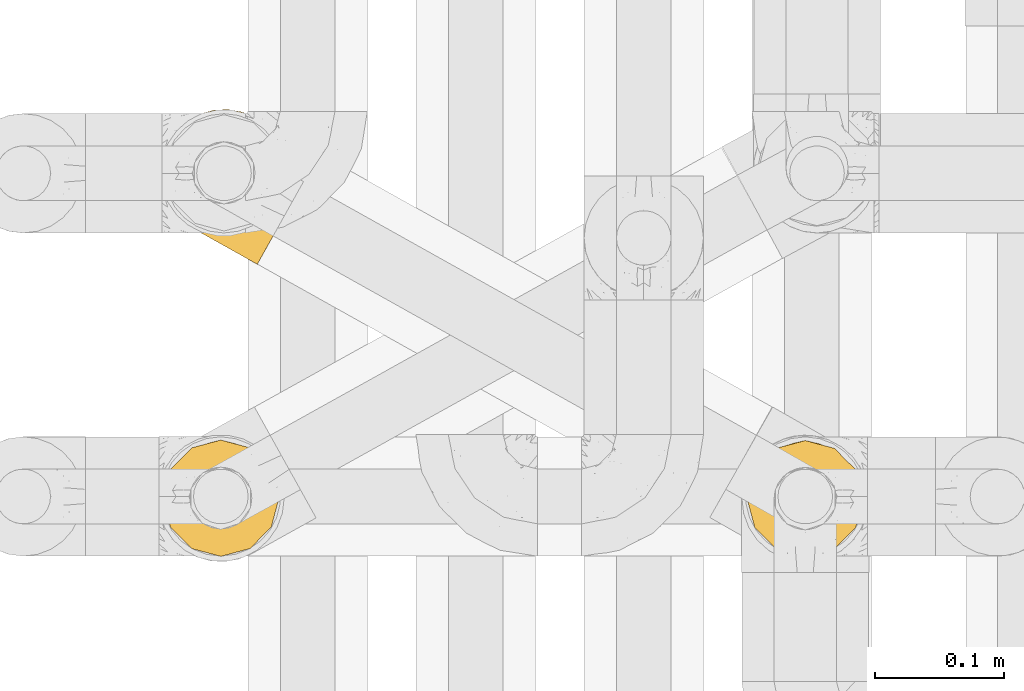
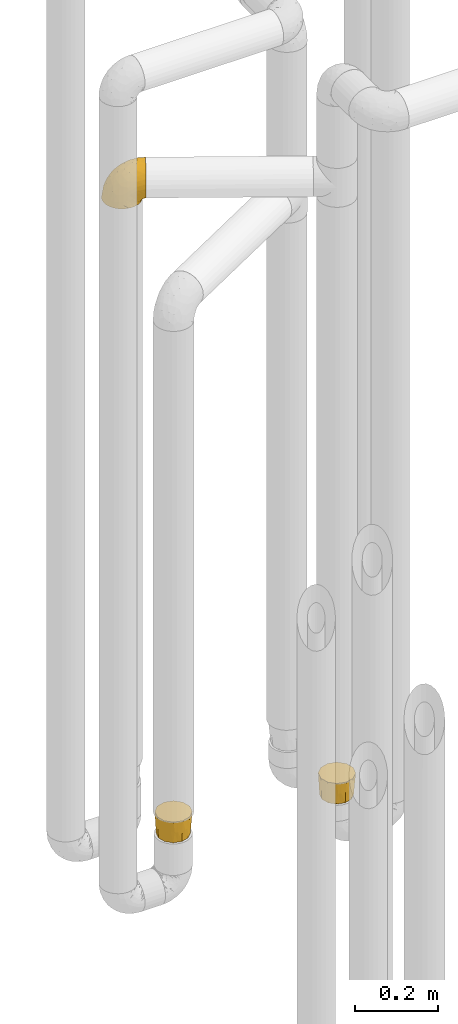
# One storey, part 178 of 827: 3 coverings.
"""IFC2X3 building model written with IfcOpenShell, lengths in millimetres."""

from ifc_helpers import new_model, entity, si_unit, converted_unit, derived_unit, direction, frame, origin, place, context, subcontext, project, spatial, faceted_brep, element, save


model = new_model("IFC2X3")

# Units and contexts
model_context = context("Model", 3, precision=0.01, world=origin(), true_north=direction((6.12303176911189e-17, 1.0)))
body_context = subcontext(model_context, "Body", "Model", "MODEL_VIEW")
ifc_project = project(units=[si_unit("LENGTHUNIT", "METRE", prefix="MILLI"), si_unit("AREAUNIT", "SQUARE_METRE"), si_unit("VOLUMEUNIT", "CUBIC_METRE"), converted_unit("PLANEANGLEUNIT", "DEGREE", entity("IfcRatioMeasure", 0.0174532925199433), si_unit("PLANEANGLEUNIT", "RADIAN"), dimensions=[0, 0, 0, 0, 0, 0, 0]), si_unit("MASSUNIT", "GRAM", prefix="KILO"), derived_unit("MASSDENSITYUNIT", [(si_unit("MASSUNIT", "GRAM", prefix="KILO"), 1), (si_unit("LENGTHUNIT", "METRE"), -3)]), derived_unit("MOMENTOFINERTIAUNIT", [(si_unit("LENGTHUNIT", "METRE"), 4)]), si_unit("TIMEUNIT", "SECOND"), si_unit("FREQUENCYUNIT", "HERTZ"), si_unit("THERMODYNAMICTEMPERATUREUNIT", "DEGREE_CELSIUS"), derived_unit("THERMALTRANSMITTANCEUNIT", [(si_unit("MASSUNIT", "GRAM", prefix="KILO"), 1), (si_unit("THERMODYNAMICTEMPERATUREUNIT", "KELVIN"), -1), (si_unit("TIMEUNIT", "SECOND"), -3)]), derived_unit("VOLUMETRICFLOWRATEUNIT", [(si_unit("LENGTHUNIT", "METRE"), 3), (si_unit("TIMEUNIT", "SECOND"), -1)]), derived_unit("MASSFLOWRATEUNIT", [(si_unit("MASSUNIT", "GRAM", prefix="KILO"), 1), (si_unit("TIMEUNIT", "SECOND"), -1)]), derived_unit("ROTATIONALFREQUENCYUNIT", [(si_unit("TIMEUNIT", "SECOND"), -1)]), si_unit("ELECTRICCURRENTUNIT", "AMPERE"), si_unit("ELECTRICVOLTAGEUNIT", "VOLT"), si_unit("POWERUNIT", "WATT"), si_unit("FORCEUNIT", "NEWTON", prefix="KILO"), si_unit("ILLUMINANCEUNIT", "LUX"), si_unit("LUMINOUSFLUXUNIT", "LUMEN"), si_unit("LUMINOUSINTENSITYUNIT", "CANDELA"), derived_unit("USERDEFINED", [(si_unit("MASSUNIT", "GRAM", prefix="KILO"), -1), (si_unit("LENGTHUNIT", "METRE"), -2), (si_unit("TIMEUNIT", "SECOND"), 3), (si_unit("LUMINOUSFLUXUNIT", "LUMEN"), 1)]), derived_unit("LINEARVELOCITYUNIT", [(si_unit("LENGTHUNIT", "METRE"), 1), (si_unit("TIMEUNIT", "SECOND"), -1)]), si_unit("PRESSUREUNIT", "PASCAL"), derived_unit("USERDEFINED", [(si_unit("LENGTHUNIT", "METRE"), -2), (si_unit("MASSUNIT", "GRAM", prefix="KILO"), 1), (si_unit("TIMEUNIT", "SECOND"), -2)]), derived_unit("LINEARFORCEUNIT", [(si_unit("MASSUNIT", "GRAM", prefix="KILO"), 1), (si_unit("LENGTHUNIT", "METRE"), 1), (si_unit("TIMEUNIT", "SECOND"), -2), (si_unit("LENGTHUNIT", "METRE"), -1)]), derived_unit("PLANARFORCEUNIT", [(si_unit("MASSUNIT", "GRAM", prefix="KILO"), 1), (si_unit("LENGTHUNIT", "METRE"), 1), (si_unit("TIMEUNIT", "SECOND"), -2), (si_unit("LENGTHUNIT", "METRE"), -2)])], contexts=[model_context])

# Site, building, storey
site_placement = place(None, origin())
site = spatial("IfcSite", under=ifc_project, at=site_placement, CompositionType="ELEMENT")
building_placement = place(site_placement, origin())
building = spatial("IfcBuilding", under=site, at=building_placement, CompositionType="ELEMENT")
storey_placement = place(building_placement, frame((0.0, 0.0, 28200.0)))
storey = spatial("IfcBuildingStorey", under=building, at=storey_placement, Name="08", CompositionType="ELEMENT", Elevation=28200.0)

# Coverings
covering_1_placement = place(storey_placement, frame((35224.69, 12934.21, 2246.4)))
element("IfcCovering", 1, at=covering_1_placement, inside=storey, Name=":ADSK_", ObjectType=":ADSK_", PredefinedType="INSULATION", context=body_context, shape_type="Brep", body=[
    faceted_brep([(26.66, 29.42, 1.6), (17.71, 35.84, 1.6), (10.42, 44.09, 1.6), (5.14, 53.75, 1.6), (2.15, 64.35, 1.6), (1.6, 75.34, 1.6), (3.5, 86.18, 1.6), (7.76, 96.32, 1.6), (14.18, 105.26, 1.6), (22.43, 112.55, 1.6), (32.09, 117.83, 1.6), (42.68, 120.82, 1.6), (53.67, 121.38, 1.6), (64.51, 119.47, 1.6), (74.65, 115.21, 1.6), (79.31, 111.87, 1.6), (83.6, 108.79, 1.6), (87.24, 104.67, 1.6), (90.89, 100.55, 1.6), (96.16, 90.88, 1.6), (99.15, 80.29, 1.6), (99.71, 69.3, 1.6), (97.81, 58.46, 1.6), (93.55, 48.32, 1.6), (87.13, 39.37, 1.6), (78.88, 32.08, 1.6), (69.22, 26.81, 1.6), (58.63, 23.82, 1.6), (47.64, 23.26, 1.6), (42.22, 24.21, 1.6), (36.8, 25.16, 1.6), (31.94, 27.2, 1.6), (29.3, 28.31, 1.6), (106.61, 55.59, 11.12), (112.4, 65.94, 16.03), (114.88, 70.38, 19.94), (117.37, 74.82, 23.84), (119.27, 78.23, 28.93), (121.18, 81.64, 34.02), (122.38, 83.78, 39.95), (123.58, 85.92, 45.87), (124.03, 86.72, 52.86), (124.21, 87.05, 55.73), (124.39, 87.38, 58.6), (123.58, 85.92, 71.32), (121.18, 81.64, 83.17), (117.37, 74.82, 93.35), (112.4, 65.94, 101.16), (106.61, 55.59, 106.07), (100.4, 44.49, 107.75), (94.19, 33.39, 106.07), (88.4, 23.04, 101.16), (83.43, 14.16, 93.35), (79.62, 7.34, 83.17), (77.22, 3.06, 71.32), (76.4, 1.6, 58.6), (76.77, 2.25, 52.86), (77.22, 3.06, 45.87), (78.42, 5.2, 39.95), (79.62, 7.34, 34.02), (81.52, 10.75, 28.93), (83.43, 14.16, 23.84), (85.91, 18.6, 19.94), (88.4, 23.04, 16.03), (94.19, 33.39, 11.12), (100.4, 44.49, 9.45), (36.56, 70.4, 81.82), (38.89, 53.31, 84.02), (50.11, 57.76, 93.05), (71.77, 60.5, 102.55), (77.54, 48.23, 104.83), (89.85, 50.39, 105.83), (52.86, 41.3, 91.87), (70.61, 41.75, 101.74), (70.42, 28.97, 97.07), (17.4, 41.01, 38.45), (20.85, 33.97, 22.17), (28.3, 30.22, 42.04), (59.66, 17.07, 77.69), (42.09, 32.24, 75.76), (38.9, 26.67, 62.11), (59.86, 12.12, 66.08), (57.36, 12.25, 54.26), (62.15, 9.57, 55.35), (66.94, 6.89, 56.44), (69.31, 5.56, 56.98), (71.67, 4.24, 57.52), (60.58, 24.87, 87.84), (13.05, 41.95, 19.41), (13.67, 81.91, 48.89), (5.2, 81.14, 26.34), (9.93, 69.76, 44.55), (30.44, 27.31, 23.41), (33.14, 25.8, 28.03), (35.83, 24.29, 32.65), (38.53, 22.78, 37.28), (41.23, 21.27, 41.9), (7.99, 50.47, 20.6), (20.71, 74.86, 63.36), (29.7, 36.89, 62.21), (2.99, 70.9, 19.94), (9.43, 95.38, 13.68), (39.68, 42.44, 80.85), (26.55, 46.45, 66.53), (26.55, 55.8, 71.06), (25.45, 86.42, 63.99), (35.7, 80.68, 75.73), (5.54, 60.58, 26.77), (27.13, 29.16, 4.31), (27.6, 28.9, 7.01), (28.54, 28.37, 12.43), (29.49, 27.84, 17.92), (13.05, 51.66, 43.43), (16.97, 56.67, 56.23), (43.73, 20.71, 54.97), (12.29, 93.78, 34.4), (45.26, 19.02, 44.99), (49.29, 16.76, 48.08), (53.33, 14.5, 51.17), (45.95, 74.95, 87.47), (28.5, 65.39, 74.55), (18.31, 65.77, 60.86), (18.87, 90.1, 49.19), (58.86, 67.73, 95.01), (37.4, 24.8, 10.27), (70.57, 5.87, 48.79), (62.38, 10.7, 45.16), (68.38, 7.92, 44.99), (82.83, 33.96, 6.17), (75.37, 28.61, 7.65), (41.37, 22.75, 21.59), (36.71, 24.48, 19.96), (78.83, 18.94, 21.0), (74.8, 14.44, 27.2), (82.61, 25.77, 14.83), (73.44, 20.48, 19.7), (78.14, 28.13, 10.93), (88.51, 35.06, 9.63), (61.74, 20.18, 19.97), (53.79, 20.29, 21.13), (59.28, 22.09, 14.14), (76.15, 11.72, 30.2), (60.19, 23.55, 8.12), (67.37, 24.74, 9.93), (63.73, 18.02, 24.62), (44.14, 23.12, 11.87), (95.55, 47.2, 7.15), (89.67, 41.06, 5.32), (44.69, 21.08, 26.68), (69.65, 23.68, 13.92), (51.22, 18.4, 30.67), (68.78, 10.84, 36.65), (58.31, 13.02, 42.89), (64.74, 13.43, 34.04), (54.58, 15.93, 36.6), (69.01, 16.32, 26.41), (51.89, 22.62, 10.07), (52.29, 21.65, 15.83), (53.83, 15.13, 41.99), (107.04, 69.44, 14.83), (107.99, 85.96, 26.4), (110.9, 76.23, 21.01), (106.77, 80.0, 19.71), (100.25, 67.84, 5.72), (88.04, 106.16, 21.6), (84.13, 109.22, 19.96), (81.13, 111.59, 28.03), (89.18, 103.6, 11.87), (99.96, 82.95, 9.93), (122.03, 88.71, 58.06), (114.93, 92.67, 56.44), (119.66, 90.03, 57.52), (97.21, 89.68, 8.13), (97.99, 91.23, 14.15), (114.81, 90.91, 44.99), (112.53, 89.04, 36.65), (115.64, 82.3, 30.2), (93.67, 97.23, 10.06), (94.69, 97.42, 15.83), (117.7, 90.12, 48.79), (105.19, 96.82, 42.89), (109.15, 94.72, 45.38), (76.53, 114.16, 12.43), (84.22, 108.48, 10.28), (102.22, 59.55, 9.64), (110.15, 95.35, 55.35), (105.36, 98.03, 54.26), (99.13, 59.13, 6.05), (75.59, 114.69, 7.01), (76.06, 114.42, 9.72), (83.83, 110.08, 32.65), (91.2, 104.21, 26.68), (102.05, 81.56, 13.92), (86.52, 108.57, 37.28), (96.93, 100.02, 30.66), (96.64, 96.87, 21.14), (100.76, 98.48, 36.59), (103.78, 89.56, 24.6), (77.48, 113.63, 17.92), (78.44, 113.09, 23.41), (102.69, 72.0, 10.93), (100.9, 90.13, 19.97), (101.05, 99.53, 41.99), (97.29, 102.55, 48.08), (108.21, 91.12, 34.04), (112.61, 82.03, 27.21), (101.32, 100.29, 51.17), (93.25, 104.8, 44.99), (89.22, 107.06, 41.9), (90.72, 105.31, 55.26), (85.25, 62.01, 104.83), (96.28, 88.69, 87.84), (80.62, 100.46, 75.91), (70.43, 97.31, 80.84), (78.23, 86.67, 91.87), (60.69, 92.34, 83.98), (56.65, 120.3, 19.16), (67.51, 117.84, 22.37), (106.77, 95.97, 66.08), (62.78, 80.4, 93.05), (87.14, 71.31, 101.74), (97.93, 78.16, 97.07), (102.45, 93.56, 77.69), (31.54, 108.37, 44.55), (19.36, 106.45, 26.34), (23.15, 98.82, 48.9), (52.07, 101.54, 70.99), (44.97, 94.82, 74.55), (59.81, 117.19, 37.8), (32.82, 96.46, 63.4), (44.92, 85.34, 81.82), (37.07, 116.91, 26.77), (46.97, 120.11, 20.6), (46.25, 109.22, 56.15), (39.27, 103.29, 60.85), (74.81, 113.4, 42.06), (66.51, 111.08, 57.03), (26.94, 113.68, 19.94), (48.67, 115.14, 43.59), (82.83, 106.21, 62.61), (60.1, 106.4, 66.52)], [[[0, 1, 2, 3, 4, 5, 6, 7, 8, 9, 10, 11, 12, 13, 14, 15, 16, 17, 18, 19, 20, 21, 22, 23, 24, 25, 26, 27, 28, 29, 30, 31, 32]], [[33, 34, 35, 36, 37, 38, 39, 40, 41, 42, 43, 44, 45, 46, 47, 48, 49, 50, 51, 52, 53, 54, 55, 56, 57, 58, 59, 60, 61, 62, 63, 64, 65]], [[66, 67, 68]], [[69, 70, 71]], [[68, 72, 73]], [[73, 72, 74]], [[75, 76, 77]], [[78, 79, 80]], [[51, 50, 73]], [[81, 82, 83, 84, 85, 86, 55]], [[52, 87, 53]], [[74, 52, 51]], [[2, 1, 88]], [[89, 90, 91]], [[77, 92, 93, 94, 95, 96]], [[55, 54, 81]], [[78, 53, 87]], [[5, 90, 6]], [[88, 76, 75]], [[97, 3, 2]], [[89, 91, 98]], [[99, 80, 79]], [[90, 5, 100]], [[74, 87, 52]], [[100, 5, 4]], [[90, 101, 6]], [[79, 102, 103]], [[102, 67, 104]], [[105, 98, 106]], [[107, 4, 3]], [[76, 0, 108, 109, 110, 111, 92]], [[107, 112, 113]], [[114, 77, 96]], [[89, 115, 90]], [[114, 96, 116, 117, 118, 82]], [[75, 97, 88]], [[119, 66, 68]], [[50, 71, 70]], [[100, 91, 90]], [[99, 77, 80]], [[102, 104, 103]], [[97, 107, 3]], [[80, 81, 78]], [[107, 97, 112]], [[68, 73, 70]], [[66, 98, 120]], [[78, 81, 54]], [[114, 81, 80]], [[53, 78, 54]], [[78, 87, 79]], [[102, 87, 72]], [[79, 103, 99]], [[4, 107, 100]], [[91, 100, 107]], [[88, 97, 2]], [[112, 97, 75]], [[99, 112, 75]], [[103, 104, 113]], [[91, 121, 98]], [[89, 105, 122, 115]], [[101, 90, 115]], [[101, 7, 6]], [[88, 1, 76]], [[0, 76, 1]], [[92, 77, 76]], [[73, 74, 51]], [[87, 74, 72]], [[81, 114, 82]], [[77, 114, 80]], [[87, 102, 79]], [[67, 102, 72]], [[68, 67, 72]], [[67, 120, 104]], [[120, 121, 104]], [[104, 121, 113]], [[121, 120, 98]], [[91, 107, 113]], [[91, 113, 121]], [[103, 113, 112]], [[66, 119, 106]], [[105, 89, 98]], [[68, 69, 123, 119]], [[67, 66, 120]], [[98, 66, 106]], [[50, 49, 71]], [[50, 70, 73]], [[112, 99, 103]], [[77, 99, 75]], [[69, 68, 70]], [[29, 124, 110]], [[84, 83, 125]], [[126, 82, 118]], [[59, 58, 127]], [[25, 128, 129]], [[130, 93, 131]], [[132, 62, 133]], [[134, 135, 136]], [[137, 65, 64]], [[64, 134, 137]], [[138, 139, 140]], [[111, 110, 124, 92]], [[134, 136, 137]], [[134, 64, 63]], [[141, 61, 60]], [[125, 58, 57]], [[142, 143, 140]], [[142, 26, 143]], [[127, 83, 82]], [[28, 124, 29]], [[108, 0, 32, 31, 30, 110, 109]], [[30, 29, 110]], [[135, 144, 138]], [[28, 145, 124]], [[57, 56, 55, 86, 85, 84]], [[146, 147, 23]], [[24, 23, 147]], [[25, 143, 26]], [[95, 94, 148]], [[24, 128, 25]], [[149, 138, 143]], [[124, 145, 131]], [[127, 58, 125]], [[150, 148, 139]], [[127, 126, 151]], [[151, 59, 127]], [[152, 151, 126]], [[153, 154, 155]], [[153, 133, 141]], [[145, 28, 27]], [[142, 156, 27]], [[157, 148, 130]], [[61, 133, 62]], [[134, 132, 135]], [[147, 128, 24]], [[65, 137, 146]], [[146, 137, 147]], [[128, 137, 136]], [[137, 128, 147]], [[128, 136, 129]], [[149, 129, 136]], [[25, 129, 143]], [[158, 152, 117]], [[152, 118, 117]], [[153, 151, 152]], [[158, 116, 154]], [[144, 150, 138]], [[153, 152, 158]], [[133, 153, 155]], [[133, 155, 132]], [[60, 151, 141]], [[135, 132, 155]], [[134, 63, 132]], [[144, 135, 155]], [[135, 138, 149]], [[155, 154, 144]], [[150, 154, 96]], [[154, 150, 144]], [[148, 94, 130]], [[82, 126, 127]], [[118, 152, 126]], [[150, 96, 95]], [[139, 148, 157]], [[150, 95, 148]], [[93, 92, 131]], [[130, 145, 156]], [[130, 94, 93]], [[84, 125, 57]], [[127, 125, 83]], [[140, 139, 157]], [[150, 139, 138]], [[140, 157, 142]], [[138, 140, 143]], [[156, 142, 157]], [[27, 26, 142]], [[130, 156, 157]], [[145, 27, 156]], [[132, 63, 62]], [[124, 131, 92]], [[130, 131, 145]], [[129, 149, 143]], [[135, 149, 136]], [[141, 133, 61]], [[60, 59, 151]], [[141, 151, 153]], [[116, 96, 154]], [[153, 158, 154]], [[158, 117, 116]], [[34, 33, 159]], [[160, 161, 162]], [[22, 21, 163]], [[164, 165, 166]], [[19, 18, 167]], [[168, 21, 20]], [[169, 43, 42, 41, 40, 170, 171]], [[172, 173, 168]], [[174, 38, 175]], [[176, 37, 36]], [[177, 164, 178]], [[40, 179, 170]], [[180, 181, 175]], [[17, 182, 183]], [[65, 146, 184]], [[185, 174, 186]], [[23, 22, 187]], [[174, 39, 38]], [[15, 14, 188, 189, 182, 16]], [[179, 40, 39]], [[190, 191, 164]], [[192, 163, 168]], [[33, 184, 159]], [[178, 173, 172]], [[193, 194, 191]], [[18, 183, 167]], [[173, 178, 195]], [[196, 197, 194]], [[198, 199, 183, 182]], [[182, 17, 16]], [[18, 17, 183]], [[200, 159, 184]], [[192, 168, 201]], [[187, 163, 200]], [[202, 203, 180]], [[185, 179, 174]], [[160, 204, 205]], [[206, 181, 180]], [[206, 180, 203]], [[199, 165, 183]], [[165, 164, 167]], [[172, 177, 178]], [[200, 192, 162]], [[205, 161, 160]], [[65, 184, 33]], [[163, 187, 22]], [[175, 204, 180]], [[174, 181, 186]], [[204, 196, 202]], [[197, 160, 162]], [[196, 207, 202]], [[205, 204, 176]], [[196, 204, 160]], [[176, 204, 175]], [[205, 35, 161]], [[34, 159, 161]], [[162, 161, 159]], [[200, 162, 159]], [[197, 162, 201]], [[194, 197, 201]], [[196, 160, 197]], [[191, 195, 178]], [[208, 196, 194]], [[186, 181, 206]], [[175, 181, 174]], [[191, 190, 193]], [[193, 208, 194]], [[195, 194, 201]], [[178, 164, 191]], [[168, 163, 21]], [[166, 165, 199]], [[166, 190, 164]], [[187, 200, 184]], [[184, 146, 187]], [[23, 187, 146]], [[174, 179, 39]], [[170, 179, 185]], [[194, 195, 191]], [[173, 201, 168]], [[201, 173, 195]], [[172, 168, 20]], [[20, 19, 172]], [[177, 172, 19]], [[19, 167, 177]], [[164, 177, 167]], [[35, 205, 36]], [[35, 34, 161]], [[183, 165, 167]], [[162, 192, 201]], [[163, 192, 200]], [[175, 38, 37]], [[205, 176, 36]], [[175, 37, 176]], [[204, 202, 180]], [[207, 196, 208]], [[207, 203, 202]], [[209, 186, 206, 203, 207, 208]], [[48, 210, 71]], [[211, 212, 213]], [[214, 213, 215]], [[216, 217, 13]], [[218, 43, 169, 171, 170, 185, 186]], [[219, 220, 214]], [[47, 46, 221]], [[210, 48, 220]], [[211, 222, 212]], [[222, 45, 44]], [[221, 220, 47]], [[47, 220, 48]], [[221, 211, 214]], [[223, 224, 225]], [[211, 46, 45]], [[226, 227, 215]], [[43, 218, 44]], [[217, 216, 228]], [[227, 229, 230]], [[14, 13, 217]], [[224, 9, 8]], [[10, 231, 11]], [[11, 232, 12]], [[233, 223, 234]], [[235, 208, 193, 190, 166, 199]], [[236, 235, 228]], [[222, 44, 218]], [[106, 230, 229]], [[224, 237, 9]], [[232, 238, 228]], [[9, 237, 10]], [[115, 224, 101]], [[239, 235, 236]], [[232, 11, 231]], [[223, 231, 237]], [[224, 8, 101]], [[223, 229, 234]], [[225, 115, 122, 105]], [[216, 12, 232]], [[209, 235, 239]], [[210, 219, 69]], [[219, 214, 215]], [[230, 119, 219]], [[209, 218, 186]], [[239, 212, 222]], [[239, 222, 218]], [[45, 222, 211]], [[236, 212, 239]], [[213, 212, 240]], [[223, 237, 224]], [[231, 10, 237]], [[238, 232, 231]], [[216, 232, 228]], [[233, 231, 223]], [[236, 238, 240]], [[115, 225, 224]], [[234, 229, 227]], [[8, 7, 101]], [[235, 209, 208]], [[218, 209, 239]], [[217, 228, 235]], [[13, 12, 216]], [[235, 199, 217]], [[217, 199, 198, 182, 189, 188, 14]], [[211, 221, 46]], [[220, 221, 214]], [[71, 210, 69]], [[71, 49, 48]], [[219, 210, 220]], [[226, 215, 213]], [[211, 213, 214]], [[226, 213, 240]], [[215, 227, 230]], [[233, 240, 238]], [[234, 227, 226]], [[233, 234, 226]], [[229, 223, 225]], [[240, 233, 226]], [[233, 238, 231]], [[225, 105, 229]], [[229, 105, 106]], [[106, 119, 230]], [[123, 69, 219, 119]], [[215, 230, 219]], [[238, 236, 228]], [[212, 236, 240]]]),
])
covering_2_placement = place(storey_placement, frame((35678.44, 12707.87, 495.0)))
element("IfcCovering", 2, at=covering_2_placement, inside=storey, Name=":ADSK_", ObjectType=":ADSK_", PredefinedType="INSULATION", context=body_context, shape_type="Brep", body=[
    faceted_brep([(77.33, 77.33, 64.0), (69.1, 85.57, 64.0), (57.85, 88.58, 64.0), (46.6, 91.6, 64.0), (35.35, 88.58, 64.0), (24.1, 85.57, 64.0), (15.86, 77.33, 64.0), (7.62, 69.1, 64.0), (4.61, 57.85, 64.0), (1.6, 46.6, 64.0), (4.61, 35.35, 64.0), (7.62, 24.1, 64.0), (15.86, 15.86, 64.0), (24.1, 7.62, 64.0), (35.35, 4.61, 64.0), (46.6, 1.6, 64.0), (57.85, 4.61, 64.0), (69.1, 7.62, 64.0), (77.33, 15.86, 64.0), (85.57, 24.1, 64.0), (88.58, 35.35, 64.0), (91.6, 46.6, 64.0), (88.58, 57.85, 64.0), (85.57, 69.1, 64.0), (82.1, 27.8, 0.0), (74.6, 20.3, 0.0), (67.1, 12.79, 0.0), (54.38, 9.39, 0.0), (46.6, 7.3, 0.0), (36.35, 10.05, 0.0), (26.1, 12.79, 0.0), (18.59, 20.3, 0.0), (11.09, 27.8, 0.0), (7.68, 40.52, 0.0), (5.6, 48.3, 0.0), (8.34, 58.55, 0.0), (11.09, 68.8, 0.0), (18.59, 76.31, 0.0), (26.1, 83.81, 0.0), (38.8, 87.21, 0.0), (46.6, 89.3, 0.0), (56.85, 86.56, 0.0), (67.1, 83.81, 0.0), (74.6, 76.31, 0.0), (82.1, 68.8, 0.0), (85.51, 56.1, 0.0), (87.6, 48.3, 0.0), (84.85, 38.05, 0.0), (30.14, 87.18, 32.0), (38.19, 89.67, 33.43), (46.6, 90.48, 32.86), (22.25, 82.89, 32.0), (4.94, 58.14, 32.0), (12.48, 73.63, 32.0), (7.79, 65.97, 32.0), (3.54, 47.43, 32.86), (6.87, 30.99, 32.0), (4.33, 39.0, 33.43), (11.15, 23.11, 32.0), (35.91, 5.8, 32.0), (20.42, 13.33, 32.0), (28.07, 8.64, 32.0), (46.6, 4.38, 32.82), (63.05, 7.72, 32.0), (55.0, 5.15, 33.43), (70.94, 12.0, 32.0), (88.25, 36.76, 32.0), (80.71, 21.27, 32.0), (85.4, 28.92, 32.0), (89.65, 47.43, 32.82), (86.32, 63.9, 32.0), (88.86, 55.82, 33.43), (82.04, 71.79, 32.0), (57.28, 89.1, 32.0), (72.77, 81.56, 32.0), (65.12, 86.25, 32.0)], [[[0, 1, 2, 3, 4, 5, 6, 7, 8, 9, 10, 11, 12, 13, 14, 15, 16, 17, 18, 19, 20, 21, 22, 23]], [[24, 25, 26, 27, 28, 29, 30, 31, 32, 33, 34, 35, 36, 37, 38, 39, 40, 41, 42, 43, 44, 45, 46, 47]], [[39, 48, 49]], [[39, 50, 40]], [[48, 39, 38]], [[5, 4, 48]], [[51, 5, 48]], [[48, 4, 49]], [[9, 8, 52]], [[53, 51, 37]], [[51, 48, 38]], [[7, 53, 54]], [[54, 53, 36]], [[37, 36, 53]], [[51, 38, 37]], [[50, 49, 3]], [[53, 6, 51]], [[6, 5, 51]], [[6, 53, 7]], [[52, 8, 54]], [[54, 35, 52]], [[54, 36, 35]], [[3, 49, 4]], [[8, 7, 54]], [[34, 55, 9, 52]], [[39, 49, 50]], [[34, 52, 35]], [[33, 56, 57]], [[33, 55, 34]], [[56, 33, 32]], [[11, 10, 56]], [[58, 11, 56]], [[56, 10, 57]], [[15, 14, 59]], [[60, 58, 31]], [[58, 56, 32]], [[13, 60, 61]], [[61, 60, 30]], [[31, 30, 60]], [[58, 32, 31]], [[55, 57, 9]], [[60, 12, 58]], [[12, 11, 58]], [[12, 60, 13]], [[59, 14, 61]], [[61, 29, 59]], [[61, 30, 29]], [[9, 57, 10]], [[14, 13, 61]], [[28, 62, 15, 59]], [[33, 57, 55]], [[28, 59, 29]], [[27, 63, 64]], [[27, 62, 28]], [[63, 27, 26]], [[17, 16, 63]], [[65, 17, 63]], [[63, 16, 64]], [[21, 20, 66]], [[67, 65, 25]], [[65, 63, 26]], [[19, 67, 68]], [[68, 67, 24]], [[25, 24, 67]], [[65, 26, 25]], [[62, 64, 15]], [[67, 18, 65]], [[18, 17, 65]], [[18, 67, 19]], [[66, 20, 68]], [[68, 47, 66]], [[68, 24, 47]], [[15, 64, 16]], [[20, 19, 68]], [[46, 69, 21, 66]], [[27, 64, 62]], [[46, 66, 47]], [[45, 70, 71]], [[45, 69, 46]], [[70, 45, 44]], [[23, 22, 70]], [[72, 23, 70]], [[70, 22, 71]], [[3, 2, 73]], [[74, 72, 43]], [[72, 70, 44]], [[1, 74, 75]], [[75, 74, 42]], [[43, 42, 74]], [[72, 44, 43]], [[69, 71, 21]], [[74, 0, 72]], [[0, 23, 72]], [[0, 74, 1]], [[73, 2, 75]], [[75, 41, 73]], [[75, 42, 41]], [[21, 71, 22]], [[2, 1, 75]], [[40, 50, 3, 73]], [[45, 71, 69]], [[40, 73, 41]]]),
])
covering_3_placement = place(storey_placement, frame((35226.31, 12708.26, 540.0)))
element("IfcCovering", 3, at=covering_3_placement, inside=storey, Name=":ADSK_", ObjectType=":ADSK_", PredefinedType="INSULATION", context=body_context, shape_type="Brep", body=[
    faceted_brep([(15.86, 15.86, 64.0), (24.1, 7.62, 64.0), (35.35, 4.61, 64.0), (46.6, 1.6, 64.0), (57.85, 4.61, 64.0), (69.1, 7.62, 64.0), (77.33, 15.86, 64.0), (85.57, 24.1, 64.0), (88.58, 35.35, 64.0), (91.6, 46.6, 64.0), (88.58, 57.85, 64.0), (85.57, 69.1, 64.0), (77.33, 77.33, 64.0), (69.1, 85.57, 64.0), (57.85, 88.58, 64.0), (46.6, 91.6, 64.0), (35.35, 88.58, 64.0), (24.1, 85.57, 64.0), (15.86, 77.33, 64.0), (7.62, 69.1, 64.0), (4.61, 57.85, 64.0), (1.6, 46.6, 64.0), (4.61, 35.35, 64.0), (7.62, 24.1, 64.0), (11.09, 68.44, 0.0), (18.59, 75.95, 0.0), (26.1, 83.45, 0.0), (38.8, 86.85, 0.0), (46.6, 88.94, 0.0), (56.85, 86.2, 0.0), (67.1, 83.45, 0.0), (74.6, 75.95, 0.0), (82.1, 68.44, 0.0), (85.51, 55.74, 0.0), (87.6, 47.94, 0.0), (84.85, 37.69, 0.0), (82.1, 27.44, 0.0), (74.6, 19.94, 0.0), (67.1, 12.44, 0.0), (54.38, 9.03, 0.0), (46.6, 6.94, 0.0), (36.35, 9.69, 0.0), (26.1, 12.44, 0.0), (18.59, 19.94, 0.0), (11.09, 27.44, 0.0), (7.68, 40.16, 0.0), (5.6, 47.94, 0.0), (8.34, 58.19, 0.0), (63.05, 7.54, 32.0), (55.0, 4.98, 33.43), (46.6, 4.2, 32.82), (70.94, 11.82, 32.0), (88.25, 36.58, 32.0), (80.71, 21.09, 32.0), (85.4, 28.74, 32.0), (89.65, 47.25, 32.82), (86.32, 63.72, 32.0), (88.86, 55.65, 33.43), (82.04, 71.61, 32.0), (57.28, 88.92, 32.0), (72.77, 81.38, 32.0), (65.12, 86.07, 32.0), (46.6, 90.3, 32.85), (30.14, 87.0, 32.0), (38.19, 89.5, 33.43), (22.25, 82.72, 32.0), (4.94, 57.96, 32.0), (12.48, 73.45, 32.0), (7.79, 65.79, 32.0), (3.54, 47.25, 32.85), (6.87, 30.81, 32.0), (4.33, 38.83, 33.43), (11.15, 22.93, 32.0), (35.91, 5.62, 32.0), (20.42, 13.16, 32.0), (28.07, 8.46, 32.0)], [[[0, 1, 2, 3, 4, 5, 6, 7, 8, 9, 10, 11, 12, 13, 14, 15, 16, 17, 18, 19, 20, 21, 22, 23]], [[24, 25, 26, 27, 28, 29, 30, 31, 32, 33, 34, 35, 36, 37, 38, 39, 40, 41, 42, 43, 44, 45, 46, 47]], [[39, 48, 49]], [[39, 50, 40]], [[48, 39, 38]], [[5, 4, 48]], [[51, 5, 48]], [[48, 4, 49]], [[9, 8, 52]], [[53, 51, 37]], [[51, 48, 38]], [[7, 53, 54]], [[54, 53, 36]], [[37, 36, 53]], [[51, 38, 37]], [[50, 49, 3]], [[53, 6, 51]], [[6, 5, 51]], [[6, 53, 7]], [[52, 8, 54]], [[54, 35, 52]], [[54, 36, 35]], [[3, 49, 4]], [[8, 7, 54]], [[34, 55, 9, 52]], [[39, 49, 50]], [[34, 52, 35]], [[33, 56, 57]], [[33, 55, 34]], [[56, 33, 32]], [[11, 10, 56]], [[58, 11, 56]], [[56, 10, 57]], [[15, 14, 59]], [[60, 58, 31]], [[58, 56, 32]], [[13, 60, 61]], [[61, 60, 30]], [[31, 30, 60]], [[58, 32, 31]], [[55, 57, 9]], [[60, 12, 58]], [[12, 11, 58]], [[12, 60, 13]], [[59, 14, 61]], [[61, 29, 59]], [[61, 30, 29]], [[9, 57, 10]], [[14, 13, 61]], [[28, 62, 15, 59]], [[33, 57, 55]], [[28, 59, 29]], [[27, 63, 64]], [[27, 62, 28]], [[63, 27, 26]], [[17, 16, 63]], [[65, 17, 63]], [[63, 16, 64]], [[21, 20, 66]], [[67, 65, 25]], [[65, 63, 26]], [[19, 67, 68]], [[68, 67, 24]], [[25, 24, 67]], [[65, 26, 25]], [[62, 64, 15]], [[67, 18, 65]], [[18, 17, 65]], [[18, 67, 19]], [[66, 20, 68]], [[68, 47, 66]], [[68, 24, 47]], [[15, 64, 16]], [[20, 19, 68]], [[46, 69, 21, 66]], [[27, 64, 62]], [[46, 66, 47]], [[45, 70, 71]], [[45, 69, 46]], [[70, 45, 44]], [[23, 22, 70]], [[72, 23, 70]], [[70, 22, 71]], [[3, 2, 73]], [[74, 72, 43]], [[72, 70, 44]], [[1, 74, 75]], [[75, 74, 42]], [[43, 42, 74]], [[72, 44, 43]], [[69, 71, 21]], [[74, 0, 72]], [[0, 23, 72]], [[0, 74, 1]], [[73, 2, 75]], [[75, 41, 73]], [[75, 42, 41]], [[21, 71, 22]], [[2, 1, 75]], [[40, 50, 3, 73]], [[45, 71, 69]], [[40, 73, 41]]]),
])

save(model, "model.ifc")
